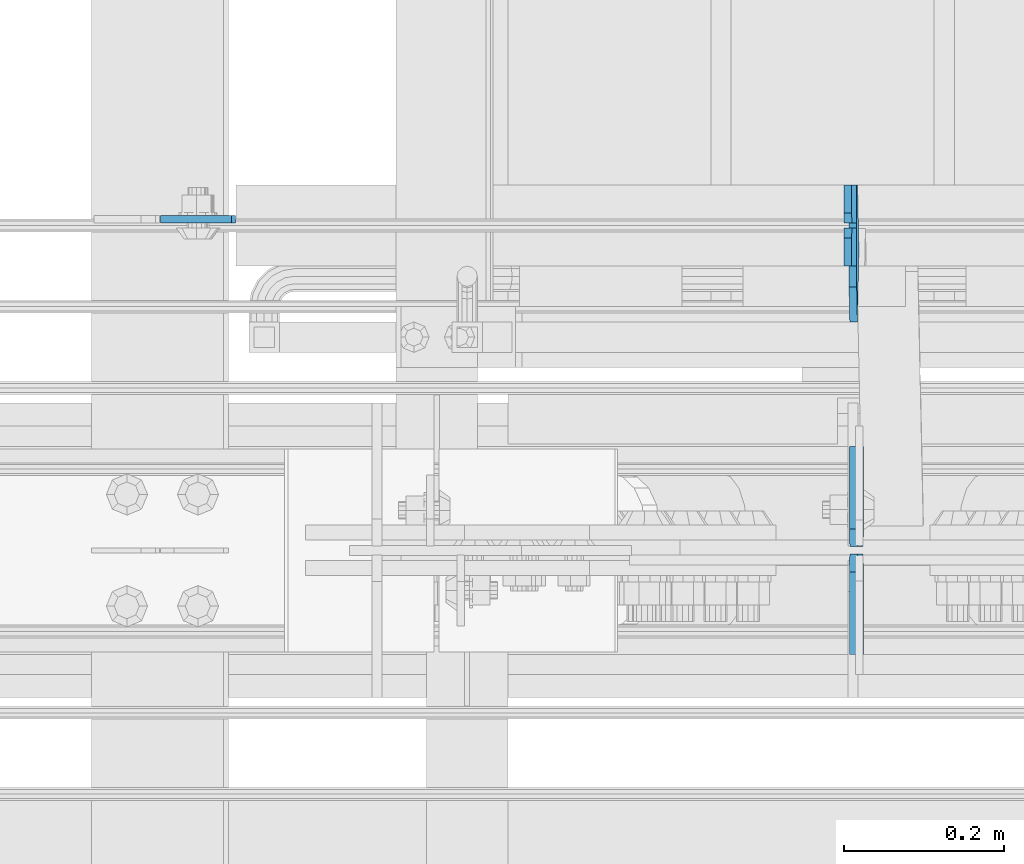
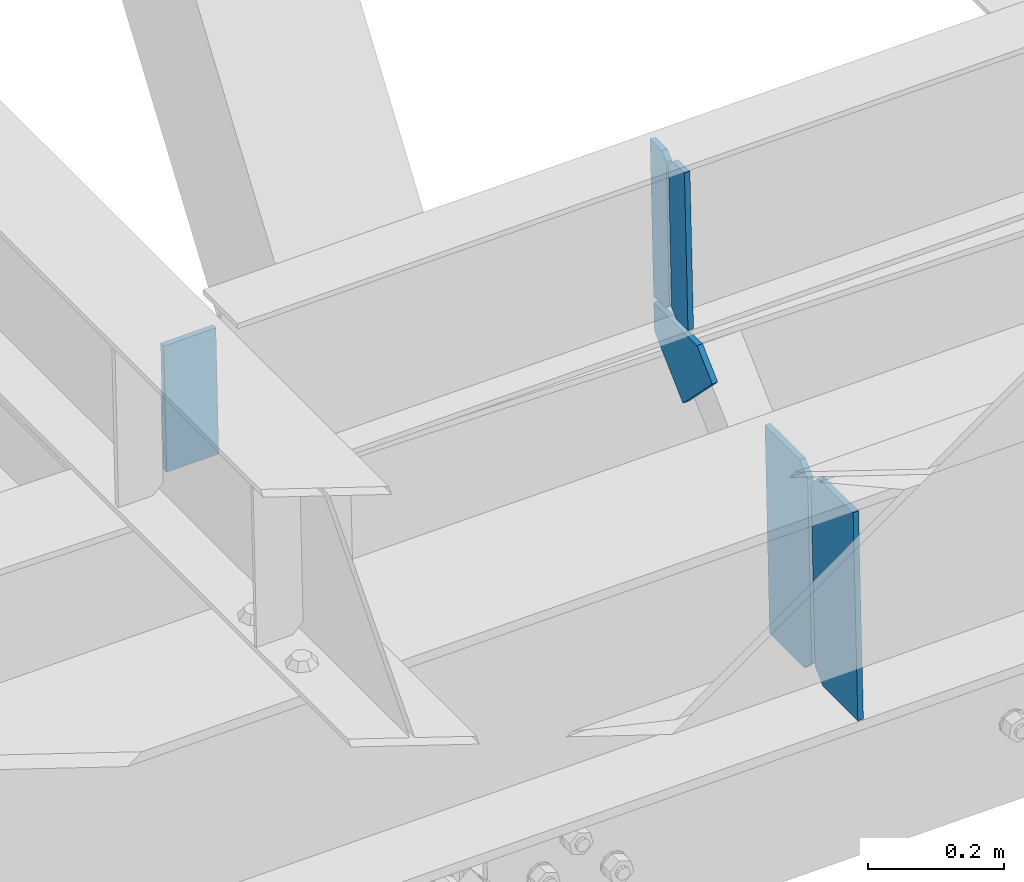
# One storey, part 3550 of 3843: 6 plates, 3 elements without a shape of their own.
"""IFC2X3 building model written with IfcOpenShell, lengths in millimetres."""

from ifc_helpers import new_model, si_unit, frame, origin_with_axes, place, context, subcontext, project, spatial, faceted_brep, material, type_object, element, aggregate, save


model = new_model("IFC2X3")

# Units and contexts
model_context = context("Model", 3, precision=1e-05, world=origin_with_axes())
body_context = subcontext(model_context, "Body", "Model", "MODEL_VIEW")
ifc_project = project(units=[si_unit("LENGTHUNIT", "METRE", prefix="MILLI"), si_unit("AREAUNIT", "SQUARE_METRE"), si_unit("VOLUMEUNIT", "CUBIC_METRE"), si_unit("MASSUNIT", "GRAM", prefix="KILO"), si_unit("TIMEUNIT", "SECOND"), si_unit("PLANEANGLEUNIT", "RADIAN"), si_unit("SOLIDANGLEUNIT", "STERADIAN"), si_unit("THERMODYNAMICTEMPERATUREUNIT", "DEGREE_CELSIUS"), si_unit("LUMINOUSINTENSITYUNIT", "LUMEN")], contexts=[model_context])

# Site, building, storey
site_placement = place(None, origin_with_axes())
site = spatial("IfcSite", under=ifc_project, at=site_placement, CompositionType="ELEMENT")
building_placement = place(site_placement, origin_with_axes())
building = spatial("IfcBuilding", under=site, at=building_placement, Name="Undefined", CompositionType="ELEMENT")
storey_placement = place(building_placement, origin_with_axes())
storey = spatial("IfcBuildingStorey", under=building, at=storey_placement, Name="Undefined", CompositionType="ELEMENT", Elevation=0.0)

# Assembly, plate
assembly_1_placement = place(storey_placement, origin_with_axes())
assembly_1 = element("IfcElementAssembly", 1, at=assembly_1_placement, inside=storey, Name="BEAM", AssemblyPlace="NOTDEFINED", PredefinedType="RIGID_FRAME")
ifc_material = material(Name="STEEL/A572-50")
plate_type_1 = type_object("IfcPlateType", PredefinedType="NOTDEFINED")
plate_1_placement = place(assembly_1_placement, frame((80464.5987096232, 15413.0375, 46620.0297907639), z_axis=(0.999776270257024, 0.0, 0.0211520550054619), x_axis=(0.0211520550054438, 0.0, -0.999776270257025)))
plate_1 = element("IfcPlate", 2, at=plate_1_placement, type_object=plate_type_1, material=ifc_material, Name="PLATE", context=body_context, shape_type="Brep", body=[
    faceted_brep([(0.0, -4.76249999999709, 0.0), (0.0, -4.76249999999709, 88.9000015258789), (0.0, 4.76249999999709, 88.9000015258789), (0.0, 4.76249999999709, 0.0), (228.600006102781, -4.7625000004191, 88.9000015257589), (228.600006102781, 4.76249999954598, 88.9000015257443), (228.600006103079, -4.7625000004482, 7.27595761418343e-12), (228.600006103079, 4.76249999954598, -7.27595761418343e-12)], [[[0, 1, 2, 3]], [[1, 4, 5, 2]], [[4, 6, 7, 5]], [[6, 0, 3, 7]], [[5, 7, 3, 2]], [[6, 4, 1, 0]]]),
])
aggregate(assembly_1, [plate_1])

# Assembly, plates
assembly_2_placement = place(storey_placement, origin_with_axes())
assembly_2 = element("IfcElementAssembly", 3, at=assembly_2_placement, inside=storey, Name="BEAM", AssemblyPlace="NOTDEFINED", PredefinedType="RIGID_FRAME")
plate_type_2 = type_object("IfcPlateType", PredefinedType="NOTDEFINED")
plate_2_placement = place(assembly_2_placement, frame((81330.4977897556, 15354.3, 46379.5290655881), z_axis=(-0.0211520980073474, 0.0, 0.999776269347241), x_axis=(0.0, 1.0, 0.0)))
plate_2 = element("IfcPlate", 4, at=plate_2_placement, type_object=plate_type_2, material=ifc_material, Name="STIFFENER", context=body_context, shape_type="Brep", body=[
    faceted_brep([(0.0, -4.76249999999709, 0.0), (0.0, -4.7624999997206, 285.749999997672), (0.0, 4.7625000002663, 285.749999997664), (0.0, 4.76249999999709, 0.0), (34.9250001907349, -4.7624999997206, 285.749999997672), (34.9250001907349, 4.7625000002663, 285.749999997664), (47.625, -4.76249999972788, 273.050000188428), (47.625, 4.76250000025902, 273.050000188421), (47.625, -4.76249999998981, 12.6999998092579), (47.625, 4.76249999999709, 12.6999998092506), (34.9250001907349, -4.76249999999709, 1.45519152283669e-11), (34.9250001907349, 4.76249999998254, 0.0)], [[[0, 1, 2, 3]], [[1, 4, 5, 2]], [[4, 6, 7, 5]], [[6, 8, 9, 7]], [[8, 10, 11, 9]], [[10, 0, 3, 11]], [[5, 7, 9, 11, 3, 2]], [[10, 8, 6, 4, 1, 0]]]),
])
plate_3_placement = place(assembly_2_placement, frame((81330.4977897556, 15408.275, 46379.5290655881), z_axis=(-0.0211520980073474, 0.0, 0.999776269347241), x_axis=(0.0, 1.0, 0.0)))
plate_3 = element("IfcPlate", 5, at=plate_3_placement, type_object=plate_type_2, material=ifc_material, Name="STIFFENER", context=body_context, shape_type="Brep", body=[
    faceted_brep([(0.0, -4.76250000000073, 12.6999998092651), (0.0, -4.76250000000073, 273.050000188858), (0.0, 4.76250000000073, 273.050000188858), (0.0, 4.76250000000073, 12.6999998092651), (12.6999998092651, -4.76250000000073, 285.749999998123), (12.6999998092651, 4.76250000000073, 285.749999998123), (47.625, -4.76250000000073, 285.749999998123), (47.625, 4.76250000000073, 285.749999998123), (47.625, -4.76250000000073, 0.0), (47.625, 4.76250000000073, 0.0), (12.6999998092651, -4.76250000000073, 0.0), (12.6999998092651, 4.76250000000073, 0.0)], [[[0, 1, 2, 3]], [[1, 4, 5, 2]], [[4, 6, 7, 5]], [[6, 8, 9, 7]], [[8, 10, 11, 9]], [[10, 0, 3, 11]], [[5, 7, 9, 11, 3, 2]], [[10, 8, 6, 4, 1, 0]]]),
])

assembly_3_placement = place(storey_placement, origin_with_axes())
assembly_3 = element("IfcElementAssembly", 6, at=assembly_3_placement, inside=storey, Name="BEAM", AssemblyPlace="NOTDEFINED", PredefinedType="RIGID_FRAME")
plate_type_3 = type_object("IfcPlateType", PredefinedType="NOTDEFINED")
plate_4_placement = place(assembly_3_placement, frame((81339.1947389234, 14868.525, 45968.458570806), z_axis=(-0.0211520980073474, 0.0, 0.999776269347241), x_axis=(0.0, 1.0, 0.0)))
plate_4 = element("IfcPlate", 7, at=plate_4_placement, type_object=plate_type_3, material=ifc_material, Name="STIFFENER", context=body_context, shape_type="Brep", body=[
    faceted_brep([(0.0, -4.76249999999709, 0.0), (0.0, -4.76249999999709, 377.824999997538), (0.0, 4.76249999999709, 377.824999997538), (0.0, 4.76249999999709, 0.0), (103.187499618536, -4.76249999999709, 377.824999997538), (103.187499618536, 4.76249999999709, 377.824999997538), (125.412500000006, -4.76249999999709, 355.599999616068), (125.412500000006, 4.76249999999709, 355.599999616068), (125.412500000006, -4.76249999999709, 22.2250003814697), (125.412500000006, 4.76249999999709, 22.2250003814697), (103.187499618536, -4.76249999999709, 0.0), (103.187499618536, 4.76249999999709, 0.0)], [[[0, 1, 2, 3]], [[1, 4, 5, 2]], [[4, 6, 7, 5]], [[6, 8, 9, 7]], [[8, 10, 11, 9]], [[10, 0, 3, 11]], [[5, 7, 9, 11, 3, 2]], [[10, 8, 6, 4, 1, 0]]]),
])
plate_5_placement = place(assembly_3_placement, frame((81339.1947389234, 15003.4625, 45968.458570806), z_axis=(-0.0211520980073474, 0.0, 0.999776269347241), x_axis=(0.0, 1.0, 0.0)))
plate_5 = element("IfcPlate", 8, at=plate_5_placement, type_object=plate_type_3, material=ifc_material, Name="STIFFENER", context=body_context, shape_type="Brep", body=[
    faceted_brep([(0.0, -4.76249999999709, 22.2250003814697), (0.0, -4.76249999999709, 355.599999616068), (0.0, 4.76249999999709, 355.599999616068), (0.0, 4.76249999999709, 22.2250003814697), (22.2250003814697, -4.76249999999709, 377.824999997538), (22.2250003814697, 4.76249999999709, 377.824999997538), (125.412500000006, -4.76249999999709, 377.824999997538), (125.412500000006, 4.76249999999709, 377.824999997538), (125.412500000006, -4.76249999999709, 0.0), (125.412500000006, 4.76249999999709, 0.0), (22.2250003814697, -4.76249999999709, 0.0), (22.2250003814697, 4.76249999999709, 0.0)], [[[0, 1, 2, 3]], [[1, 4, 5, 2]], [[4, 6, 7, 5]], [[6, 8, 9, 7]], [[8, 10, 11, 9]], [[10, 0, 3, 11]], [[5, 7, 9, 11, 3, 2]], [[10, 8, 6, 4, 1, 0]]]),
])
aggregate(assembly_3, [plate_4, plate_5])

# Plate
plate_type_4 = type_object("IfcPlateType", PredefinedType="NOTDEFINED")
plate_6_placement = place(assembly_2_placement, frame((81330.7328421347, 15327.9974243659, 46368.4190517794), z_axis=(0.0149567919991071, 0.70710678095505, -0.706948579955064), x_axis=(0.0149567919892506, -0.707106781418042, -0.706948579492178)))
plate_6 = element("IfcPlate", 9, at=plate_6_placement, type_object=plate_type_4, material=ifc_material, Name="PLATE", context=body_context, shape_type="Brep", body=[
    faceted_brep([(0.0, -4.76249999999709, 0.0), (-90.4407785346557, -4.7624999996915, 90.4407785903313), (-90.4407785346702, 4.76250000022992, 90.4407785903604), (0.0, 4.76249999999709, 0.0), (-53.8870295345769, -4.76249999940046, 127.000000010928), (-53.8870295345769, 4.76250000053551, 127.000000010928), (61.3210243802823, -4.76249999909487, 127.00000001915), (61.3210243802605, 4.7625000008411, 127.00000001915), (61.3210243731082, -4.76249999982247, 5.82076609134674e-11), (61.321024373101, 4.7625000001135, 4.36557456851006e-11)], [[[0, 1, 2, 3]], [[1, 4, 5, 2]], [[4, 6, 7, 5]], [[6, 8, 9, 7]], [[8, 0, 3, 9]], [[5, 7, 9, 3, 2]], [[8, 6, 4, 1, 0]]]),
])

aggregate(assembly_2, [plate_2, plate_3, plate_6])

save(model, "model.ifc")
